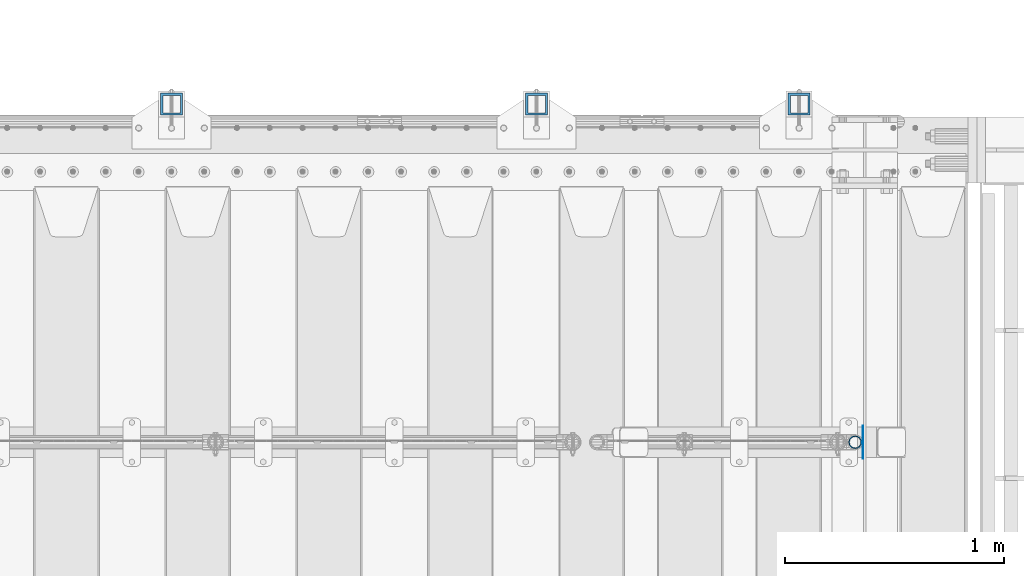
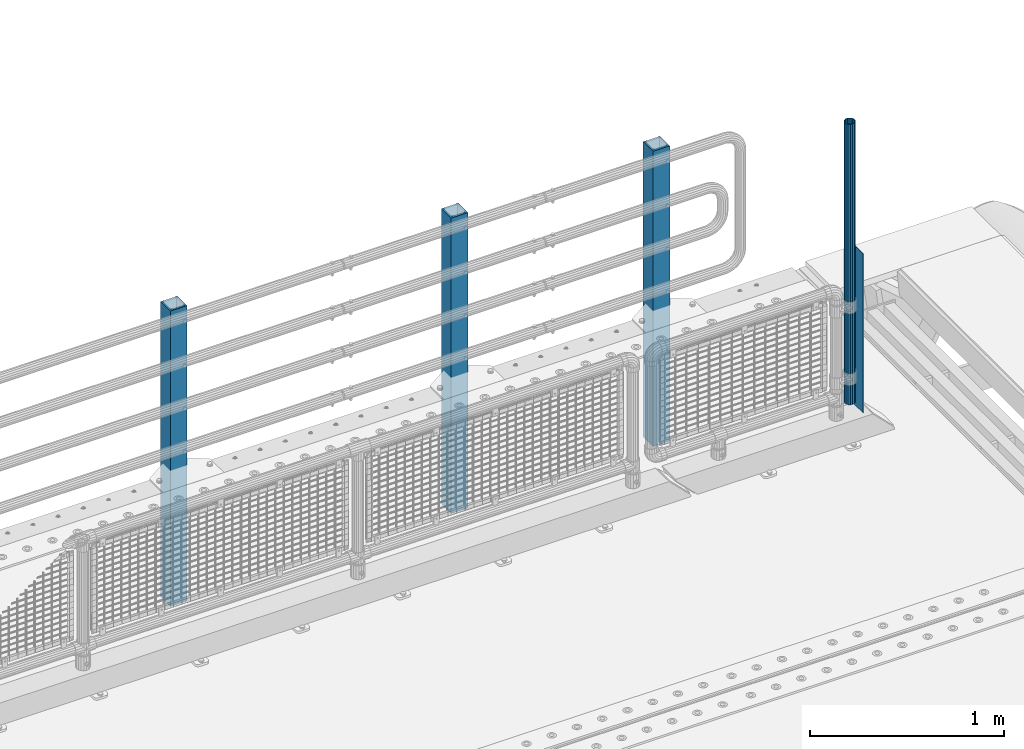
# One storey, part 65 of 270: 5 columns.
"""IFC2X3 building model written with IfcOpenShell, lengths in millimetres."""

from ifc_helpers import new_model, si_unit, frame, origin_with_axes, place, context, subcontext, project, spatial, faceted_brep, material, type_object, element, save


model = new_model("IFC2X3")

# Units and contexts
model_context = context("Model", 3, precision=1e-05, world=origin_with_axes())
body_context = subcontext(model_context, "Body", "Model", "MODEL_VIEW")
ifc_project = project(units=[si_unit("LENGTHUNIT", "METRE", prefix="MILLI"), si_unit("AREAUNIT", "SQUARE_METRE"), si_unit("VOLUMEUNIT", "CUBIC_METRE"), si_unit("MASSUNIT", "GRAM", prefix="KILO"), si_unit("TIMEUNIT", "SECOND"), si_unit("PLANEANGLEUNIT", "RADIAN"), si_unit("SOLIDANGLEUNIT", "STERADIAN"), si_unit("THERMODYNAMICTEMPERATUREUNIT", "DEGREE_CELSIUS"), si_unit("LUMINOUSINTENSITYUNIT", "LUMEN")], contexts=[model_context])

# Site, building, storey
site_placement = place(None, origin_with_axes())
site = spatial("IfcSite", under=ifc_project, at=site_placement, CompositionType="ELEMENT")
building_placement = place(site_placement, origin_with_axes())
building = spatial("IfcBuilding", under=site, at=building_placement, Name="Standard", CompositionType="ELEMENT")
storey_placement = place(building_placement, origin_with_axes())
storey = spatial("IfcBuildingStorey", under=building, at=storey_placement, Name="Undefined", CompositionType="ELEMENT", Elevation=0.0)

# Columns
ifc_material_1 = material(Name="Misc_Undefined")
column_type_1 = type_object("IfcColumnType", PredefinedType="NOTDEFINED")
column_1_placement = place(storey_placement, frame((19910.5, -16335.5, 200.000000000001), z_axis=(0.0, 1.0, 0.0), x_axis=(0.0, 0.0, 1.0)))
element("IfcColumn", 1, at=column_1_placement, inside=storey, type_object=column_type_1, material=ifc_material_1, context=body_context, shape_type="Brep", body=[
    faceted_brep([(0.0, 1.5, -75.0), (0.0, 1.5, 75.0), (1000.0, 1.5, 75.0), (1000.0, 1.5, -75.0), (0.0, -1.5, 75.0), (1000.0, -1.5, 75.0), (0.0, -1.5, -75.0), (1000.0, -1.5, -75.0)], [[[0, 1, 2, 3]], [[1, 4, 5, 2]], [[4, 6, 7, 5]], [[6, 0, 3, 7]], [[5, 7, 3, 2]], [[6, 4, 1, 0]]]),
])
column_type_2 = type_object("IfcColumnType", PredefinedType="NOTDEFINED")
column_2_placement = place(storey_placement, frame((19874.0, -16335.5, 238.020000000002), z_axis=(-1.0, 0.0, 0.0), x_axis=(0.0, 0.0, 1.0)))
element("IfcColumn", 2, at=column_2_placement, inside=storey, type_object=column_type_2, material=ifc_material_1, context=body_context, shape_type="Brep", body=[
    faceted_brep([(0.0, -25.3500000000004, 0.0), (0.0, -23.4203461491616, 9.70102501045403), (1761.98, -23.4203461491616, 9.70102501045403), (1761.98, -25.3500000000004, 0.0), (0.0, -17.9251569030785, 17.9251569030785), (1761.98, -17.9251569030785, 17.9251569030785), (0.0, -9.70102501045585, 23.4203461491597), (1761.98, -9.70102501045585, 23.4203461491597), (0.0, 0.0, 25.3499999999985), (1761.98, 0.0, 25.3499999999985), (0.0, 9.70102501045585, 23.4203461491597), (1761.98, 9.70102501045585, 23.4203461491597), (0.0, 17.9251569030785, 17.9251569030785), (1761.98, 17.9251569030785, 17.9251569030785), (0.0, 23.4203461491616, 9.70102501045403), (1761.98, 23.4203461491616, 9.70102501045403), (0.0, 25.3500000000004, 0.0), (1761.98, 25.3500000000004, 0.0), (0.0, 23.4203461491616, -9.70102501045403), (1761.98, 23.4203461491616, -9.70102501045403), (0.0, 17.9251569030785, -17.9251569030785), (1761.98, 17.9251569030785, -17.9251569030785), (0.0, 9.70102501045585, -23.4203461491597), (1761.98, 9.70102501045585, -23.4203461491597), (0.0, 0.0, -25.3499999999985), (1761.98, 0.0, -25.3499999999985), (0.0, -9.70102501045585, -23.4203461491597), (1761.98, -9.70102501045585, -23.4203461491597), (0.0, -17.9251569030785, -17.9251569030785), (1761.98, -17.9251569030785, -17.9251569030785), (0.0, -23.4203461491616, -9.70102501045403), (1761.98, -23.4203461491616, -9.70102501045403), (0.0, -30.1499999999996, 0.0), (0.0, -27.8549679052157, -11.5379054858058), (1761.98, -27.8549679052157, -11.5379054858058), (1761.98, -30.1499999999996, 0.0), (0.0, -21.3192694527752, -21.3192694527752), (1761.98, -21.3192694527752, -21.3192694527752), (0.0, -11.5379054858076, -27.8549679052157), (1761.98, -11.5379054858076, -27.8549679052157), (0.0, 0.0, -30.1500000000015), (1761.98, 0.0, -30.1500000000015), (0.0, 11.5379054858076, -27.8549679052157), (1761.98, 11.5379054858076, -27.8549679052157), (0.0, 21.3192694527752, -21.3192694527752), (1761.98, 21.3192694527752, -21.3192694527752), (0.0, 27.8549679052157, -11.5379054858058), (1761.98, 27.8549679052157, -11.5379054858058), (0.0, 30.1499999999996, 0.0), (1761.98, 30.1499999999996, 0.0), (0.0, 27.8549679052157, 11.5379054858058), (1761.98, 27.8549679052157, 11.5379054858058), (0.0, 21.3192694527752, 21.3192694527752), (1761.98, 21.3192694527752, 21.3192694527752), (0.0, 11.5379054858076, 27.8549679052157), (1761.98, 11.5379054858076, 27.8549679052157), (0.0, 0.0, 30.1500000000015), (1761.98, 0.0, 30.1500000000015), (0.0, -11.5379054858076, 27.8549679052157), (1761.98, -11.5379054858076, 27.8549679052157), (0.0, -21.3192694527752, 21.3192694527752), (1761.98, -21.3192694527752, 21.3192694527752), (0.0, -27.8549679052157, 11.5379054858058), (1761.98, -27.8549679052157, 11.5379054858058)], [[[0, 1, 2, 3]], [[1, 4, 5, 2]], [[4, 6, 7, 5]], [[6, 8, 9, 7]], [[8, 10, 11, 9]], [[10, 12, 13, 11]], [[12, 14, 15, 13]], [[14, 16, 17, 15]], [[16, 18, 19, 17]], [[18, 20, 21, 19]], [[20, 22, 23, 21]], [[22, 24, 25, 23]], [[24, 26, 27, 25]], [[26, 28, 29, 27]], [[28, 30, 31, 29]], [[30, 0, 3, 31]], [[32, 33, 34, 35]], [[33, 36, 37, 34]], [[36, 38, 39, 37]], [[38, 40, 41, 39]], [[40, 42, 43, 41]], [[42, 44, 45, 43]], [[44, 46, 47, 45]], [[46, 48, 49, 47]], [[48, 50, 51, 49]], [[50, 52, 53, 51]], [[52, 54, 55, 53]], [[54, 56, 57, 55]], [[56, 58, 59, 57]], [[58, 60, 61, 59]], [[60, 62, 63, 61]], [[62, 32, 35, 63]], [[37, 39, 41, 43, 45, 47, 49, 51, 53, 55, 57, 59, 61, 63, 35, 34], [5, 7, 9, 11, 13, 15, 17, 19, 21, 23, 25, 27, 29, 31, 3, 2]], [[62, 60, 58, 56, 54, 52, 50, 48, 46, 44, 42, 40, 38, 36, 33, 32], [30, 28, 26, 24, 22, 20, 18, 16, 14, 12, 10, 8, 6, 4, 1, 0]]]),
])
ifc_material_2 = material()
column_type_3 = type_object("IfcColumnType", PredefinedType="NOTDEFINED")
for number, where, z_axis, x_axis in (
    (3, (19618.0000000001, -14789.9999999998, -844.999999999998), (0.0, -1.0, 0.0), (0.0, 0.0, 1.0)),
    (4, (18418.0000000001, -14789.9999999998, -844.999999999998), (0.0, -1.0, 0.0), (0.0, 0.0, 1.0)),
    (5, (16750.0000000001, -14789.9999999998, -844.999999999998), (0.0, -1.0, 0.0), (0.0, 0.0, 1.0)),
):
    element("IfcColumn", number, at=place(storey_placement, frame(where, z_axis=z_axis, x_axis=x_axis)), inside=storey, type_object=column_type_3, material=ifc_material_2, context=body_context, shape_type="Brep", body=[
        faceted_brep([(0.0, 40.0, -40.0), (0.0, -40.0, -40.0), (1855.0, -40.0, -40.0), (1855.0, 40.0, -40.0), (0.0, -40.0, 40.0), (1855.0, -40.0, 40.0), (0.0, 40.0, 40.0), (1855.0, 40.0, 40.0), (0.0, 50.0, -50.0), (0.0, 50.0, 50.0), (1855.0, 50.0, 50.0), (1855.0, 50.0, -50.0), (0.0, -50.0, 50.0), (1855.0, -50.0, 50.0), (0.0, -50.0, -50.0), (1855.0, -50.0, -50.0)], [[[0, 1, 2, 3]], [[1, 4, 5, 2]], [[4, 6, 7, 5]], [[6, 0, 3, 7]], [[8, 9, 10, 11]], [[9, 12, 13, 10]], [[12, 14, 15, 13]], [[14, 8, 11, 15]], [[13, 15, 11, 10], [5, 7, 3, 2]], [[14, 12, 9, 8], [6, 4, 1, 0]]]),
    ])

save(model, "model.ifc")
